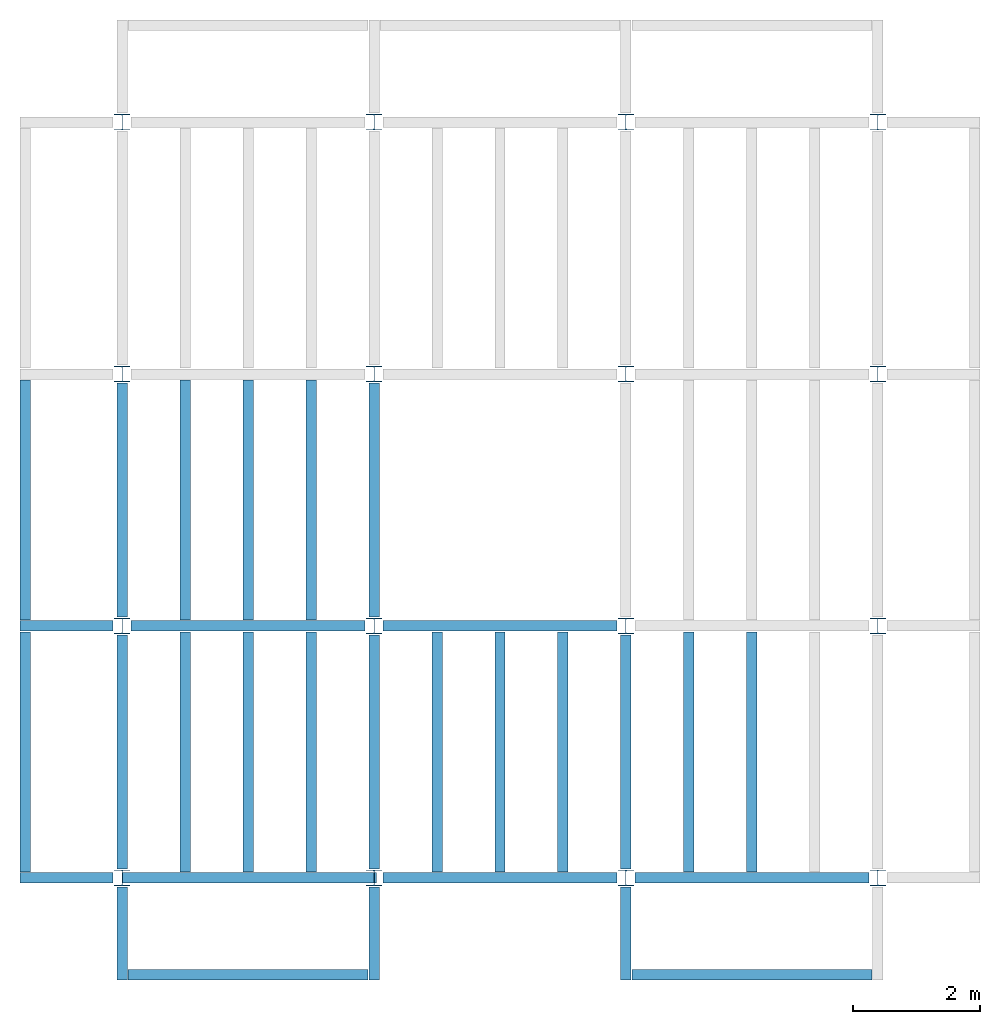
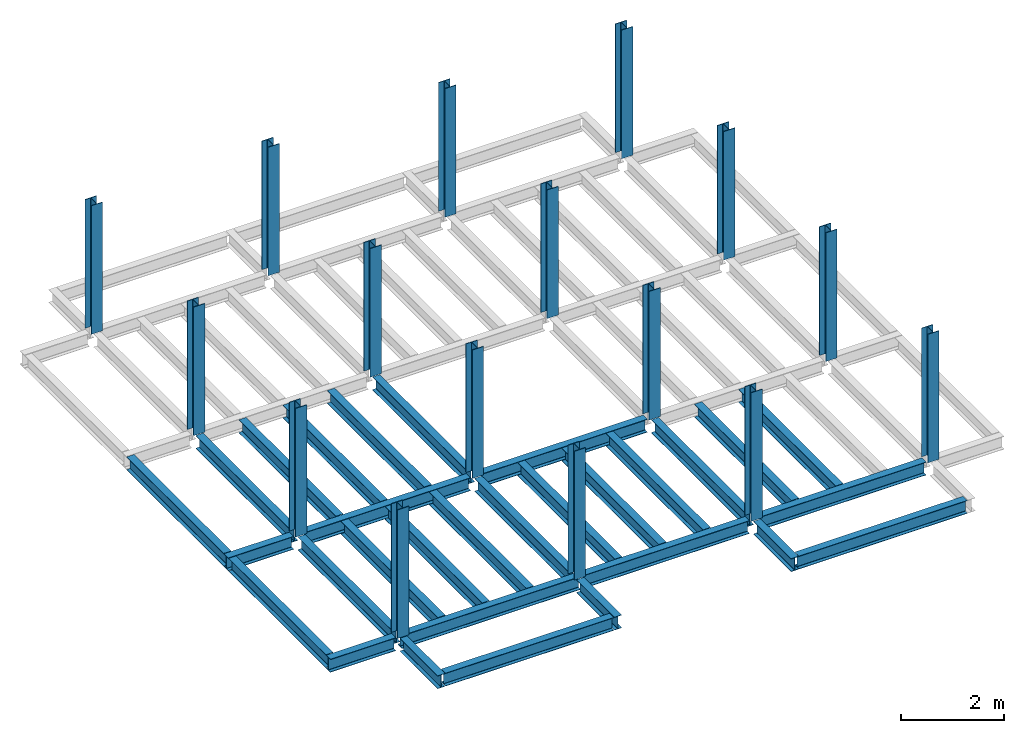
# One storey, part 1 of 3: 30 beams, 16 columns, 4 elements without a shape of their own.
"""IFC4 building model written with IfcOpenShell, lengths in feet."""

from ifc_helpers import new_model, entity, si_unit, converted_unit, derived_unit, direction, frame, origin, origin_2d, place, context, subcontext, project, spatial, line, arc, indexed_curve, i_section, outline, extrude, source, transform, mapped, material, type_object, type_shapes, element, aggregate, save


model = new_model("IFC4")

# Units and contexts
model_context = context("Model", 3, precision=0.0001, world=origin(), true_north=direction((6.123233995736766e-17, 1.0)))
plan_context = context("Plan", 3, precision=0.0001, world=origin(), true_north=direction((6.123233995736766e-17, 1.0)))
body_context = subcontext(model_context, "Body", "Model", "MODEL_VIEW")
ifc_project = project(units=[converted_unit("LENGTHUNIT", "FOOT", entity("IfcLengthMeasure", 0.3048), si_unit("LENGTHUNIT", "METRE"), dimensions=[1, 0, 0, 0, 0, 0, 0]), converted_unit("AREAUNIT", "SQUARE FOOT", entity("IfcAreaMeasure", 0.09290304), si_unit("AREAUNIT", "SQUARE_METRE"), dimensions=[2, 0, 0, 0, 0, 0, 0]), converted_unit("PLANEANGLEUNIT", "DEGREE", entity("IfcPlaneAngleMeasure", 0.017453292519943278), si_unit("PLANEANGLEUNIT", "RADIAN"), dimensions=[0, 0, 0, 0, 0, 0, 0]), converted_unit("VOLUMEUNIT", "CUBIC FOOT", entity("IfcVolumeMeasure", 0.028316846592000004), si_unit("VOLUMEUNIT", "CUBIC_METRE"), dimensions=[3, 0, 0, 0, 0, 0, 0]), si_unit("PRESSUREUNIT", "PASCAL"), derived_unit("MASSDENSITYUNIT", [(si_unit("MASSUNIT", "GRAM", prefix="KILO"), 1), (si_unit("LENGTHUNIT", "METRE"), -3)]), derived_unit("VAPORPERMEABILITYUNIT", [(si_unit("LENGTHUNIT", "METRE"), -1), (si_unit("TIMEUNIT", "SECOND"), 1)]), derived_unit("USERDEFINED", [(si_unit("MASSUNIT", "GRAM", prefix="KILO"), 1), (si_unit("LENGTHUNIT", "METRE"), 3), (si_unit("TIMEUNIT", "SECOND"), -3), (si_unit("ELECTRICCURRENTUNIT", "AMPERE"), -2)]), derived_unit("MODULUSOFELASTICITYUNIT", [(si_unit("MASSUNIT", "GRAM", prefix="KILO"), 1), (si_unit("LENGTHUNIT", "METRE"), -1), (si_unit("TIMEUNIT", "SECOND"), -2)]), derived_unit("THERMALEXPANSIONCOEFFICIENTUNIT", [(si_unit("THERMODYNAMICTEMPERATUREUNIT", "KELVIN"), -1)]), derived_unit("SPECIFICHEATCAPACITYUNIT", [(si_unit("TIMEUNIT", "SECOND"), -2), (si_unit("THERMODYNAMICTEMPERATUREUNIT", "KELVIN"), -1), (si_unit("LENGTHUNIT", "METRE"), 2)]), derived_unit("THERMALCONDUCTANCEUNIT", [(si_unit("MASSUNIT", "GRAM", prefix="KILO"), 1), (si_unit("TIMEUNIT", "SECOND"), -3), (si_unit("THERMODYNAMICTEMPERATUREUNIT", "KELVIN"), -1), (si_unit("LENGTHUNIT", "METRE"), 1)])], contexts=[model_context, plan_context])

# Site, building, storey
site_placement = place(None, origin())
site = spatial("IfcSite", under=ifc_project, at=site_placement, CompositionType="ELEMENT")
building_placement = place(site_placement, origin())
building = spatial("IfcBuilding", under=site, at=building_placement, CompositionType="ELEMENT")
storey_placement = place(building_placement, frame((0.0, 0.0, 29.875)))
storey = spatial("IfcBuildingStorey", under=building, at=storey_placement, Name="STR 04", CompositionType="ELEMENT", Elevation=29.875)

# Columns
ifc_material = material(Name="Steel ASTM A992", Category="Metal")
column_type = type_object("IfcColumnType", Name="W10X49", PredefinedType="COLUMN", material=ifc_material)
shared_shape_1 = source(origin(), body_context, "Body", "SweptSolid", [
    extrude(outline(indexed_curve([(-0.41666666666666663, -0.4166666666666676), (0.41666666666666663, -0.4166666666666676), (0.41666666666666663, -0.3699999999999996), (0.055833333333333846, -0.3699999999999996), (0.02637055078389421, -0.35779611588277277), (0.014166666666666636, -0.32833333333333287), (0.01416666666666665, 0.32833333333333303), (0.026370550783893467, 0.3577961158827727), (0.05583333333333332, 0.3700000000000003), (0.41666666666666663, 0.3700000000000003), (0.41666666666666663, 0.4166666666666656), (-0.41666666666666663, 0.4166666666666656), (-0.41666666666666663, 0.3700000000000003), (-0.05583333333333365, 0.3700000000000003), (-0.02637055078389416, 0.3577961158827734), (-0.014166666666666685, 0.32833333333333387), (-0.014166666666666685, -0.32833333333333264), (-0.026370550783893578, -0.3577961158827721), (-0.055833333333333374, -0.3699999999999996), (-0.41666666666666663, -0.3699999999999996)], segments=[line(1, 2, 3, 4), arc(4, 5, 6), line(6, 7), arc(7, 8, 9), line(9, 10, 11, 12, 13, 14), arc(14, 15, 16), line(16, 17), arc(17, 18, 19), line(19, 20, 1)], self_intersect=False)), frame((0.0, 0.0, 29.875), z_axis=(0.0, 0.0, 1.0), x_axis=(-1.0, 0.0, 0.0)), (0.0, 0.0, 1.0), 10.0),
])
type_shapes(column_type, [shared_shape_1])
for number, where, z_axis, x_axis, name in (
    (1, (0.0, 0.0, -29.875), (0.0, 0.0, 1.0), (-1.0, 0.0, 0.0), "W10X49"),
    (2, (0.0, 13.0, -29.875), (0.0, 0.0, 1.0), (-1.0, 0.0, 0.0), "W10X49"),
    (3, (0.0, 26.0, -29.875), (0.0, 0.0, 1.0), (-1.0, 0.0, 0.0), "W10X49"),
    (4, (0.0, 39.0, -29.875), (0.0, 0.0, 1.0), (-1.0, 0.0, 0.0), "W10X49"),
    (5, (13.0, 0.0, -29.875), (0.0, 0.0, 1.0), (-1.0, 0.0, 0.0), "W10X49"),
    (6, (13.0, 13.0, -29.875), (0.0, 0.0, 1.0), (-1.0, 0.0, 0.0), "W10X49"),
    (7, (13.0, 26.0, -29.875), (0.0, 0.0, 1.0), (-1.0, 0.0, 0.0), "W10X49"),
    (8, (13.0, 39.0, -29.875), (0.0, 0.0, 1.0), (-1.0, 0.0, 0.0), "W10X49"),
    (9, (26.0, 0.0, -29.875), (0.0, 0.0, 1.0), (-1.0, 0.0, 0.0), "W10X49"),
    (10, (26.0, 13.0, -29.875), (0.0, 0.0, 1.0), (-1.0, 0.0, 0.0), "W10X49"),
    (11, (26.0, 26.0, -29.875), (0.0, 0.0, 1.0), (-1.0, 0.0, 0.0), "W10X49"),
    (12, (26.0, 39.0, -29.875), (0.0, 0.0, 1.0), (-1.0, 0.0, 0.0), "W10X49"),
    (13, (39.0, 0.0, -29.875), (0.0, 0.0, 1.0), (-1.0, 0.0, 0.0), "W10X49"),
    (14, (39.0, 13.0, -29.875), (0.0, 0.0, 1.0), (-1.0, 0.0, 0.0), "W10X49"),
    (15, (39.0, 26.0, -29.875), (0.0, 0.0, 1.0), (-1.0, 0.0, 0.0), "W10X49"),
    (16, (39.0, 39.0, -29.875), (0.0, 0.0, 1.0), (-1.0, 0.0, 0.0), "W10X49"),
):
    element("IfcColumn", number, at=place(storey_placement, frame(where, z_axis=z_axis, x_axis=x_axis)), inside=storey, type_object=column_type, material=ifc_material, Name=name, ObjectType="W Shapes-Column:W10X49", PredefinedType="COLUMN", context=body_context, shape_type="MappedRepresentation", body=[
        mapped(shared_shape_1, transform((0.0, 0.0, 0.0), scale=1.0)),
    ])

# Beams
beam_type_1 = type_object("IfcBeamType", Name="W12X26", PredefinedType="JOIST", material=ifc_material)
shared_shape_2 = source(origin(), body_context, "Body", "SweptSolid", [
    extrude(outline(indexed_curve([(-0.27041666666666714, -0.47666666666666574), (-0.27041666666666714, -0.5083333333333351), (0.2704166666666669, -0.5083333333333351), (0.2704166666666669, -0.47666666666666574), (0.03458333333333309, -0.47666666666666574), (0.016905663803669493, -0.46934433619632937), (0.009583333333333202, -0.4516666666666659), (0.0095833333333332, 0.45166666666666705), (0.01690566380366948, 0.4693443361963307), (0.03458333333333325, 0.4766666666666671), (0.2704166666666669, 0.4766666666666671), (0.2704166666666669, 0.5083333333333312), (-0.2704166666666655, 0.5083333333333312), (-0.2704166666666655, 0.4766666666666671), (-0.034583333333333514, 0.47666666666666707), (-0.016905663803669865, 0.46934433619633054), (-0.009583333333333737, 0.45166666666666694), (-0.009583333333333735, -0.4516666666666658), (-0.01690566380367013, -0.4693443361963295), (-0.03458333333333368, -0.47666666666666574)], segments=[line(1, 2, 3, 4, 5), arc(5, 6, 7), line(7, 8), arc(8, 9, 10), line(10, 11, 12, 13, 14, 15), arc(15, 16, 17), line(17, 18), arc(18, 19, 20), line(20, 1)], self_intersect=False)), frame((-6.103346456692914, 0.0, 0.0), z_axis=(-1.0, 0.0, 0.0), x_axis=(0.0, -1.0, 0.0)), (0.0, 0.0, -1.0), 12.083333333333323),
])
type_shapes(beam_type_1, [shared_shape_2])
beam_1_placement = place(storey_placement, frame((6.561679790026266, 13.0, -0.5083333333333329)))
element("IfcBeam", 17, at=beam_1_placement, inside=storey, type_object=beam_type_1, material=ifc_material, Name="W12X26", ObjectType="W Shapes:W12X26", PredefinedType="JOIST", context=body_context, shape_type="MappedRepresentation", body=[
    mapped(shared_shape_2, transform((0.0, 0.0, 0.0), scale=1.0)),
])
for number, where, z_axis, x_axis, name in (
    (18, (0.0, 6.561679790026247, -0.5083333333333329), (0.0, 0.0, 1.0), (0.0, 1.0, 0.0), "W12X26"),
    (19, (26.0, 6.561679790026162, -0.5083333333333329), (0.0, 0.0, 1.0), (0.0, 1.0, 0.0), "W12X26"),
    (20, (13.0, 6.561679790026203, -0.5083333333333329), (0.0, 0.0, 1.0), (0.0, 1.0, 0.0), "W12X26"),
):
    element("IfcBeam", number, at=place(storey_placement, frame(where, z_axis=z_axis, x_axis=x_axis)), inside=storey, type_object=beam_type_1, material=ifc_material, Name=name, ObjectType="W Shapes:W12X26", PredefinedType="JOIST", context=body_context, shape_type="MappedRepresentation", body=[
        mapped(shared_shape_2, transform((0.0, 0.0, 0.0), scale=1.0)),
    ])
beam_type_2 = type_object("IfcBeamType", Name="W12X26", PredefinedType="JOIST", material=ifc_material)
shared_shape_3 = source(origin(), body_context, "Body", "SweptSolid", [
    extrude(outline(indexed_curve([(-0.27041666666666714, -0.47666666666666574), (-0.27041666666666714, -0.5083333333333351), (0.2704166666666669, -0.5083333333333351), (0.2704166666666669, -0.47666666666666574), (0.03458333333333309, -0.47666666666666574), (0.016905663803669493, -0.46934433619632937), (0.009583333333333202, -0.4516666666666659), (0.0095833333333332, 0.45166666666666705), (0.01690566380366948, 0.4693443361963307), (0.03458333333333325, 0.4766666666666671), (0.2704166666666669, 0.4766666666666671), (0.2704166666666669, 0.5083333333333312), (-0.2704166666666655, 0.5083333333333312), (-0.2704166666666655, 0.4766666666666671), (-0.034583333333333514, 0.47666666666666707), (-0.016905663803669865, 0.46934433619633054), (-0.009583333333333737, 0.45166666666666694), (-0.009583333333333735, -0.4516666666666658), (-0.01690566380367013, -0.4693443361963295), (-0.03458333333333368, -0.47666666666666574)], segments=[line(1, 2, 3, 4, 5), arc(5, 6, 7), line(7, 8), arc(8, 9, 10), line(10, 11, 12, 13, 14, 15), arc(15, 16, 17), line(17, 18), arc(18, 19, 20), line(20, 1)], self_intersect=False)), frame((-6.226706036745409, 0.0, 0.0), z_axis=(-1.0, 0.0, 0.0), x_axis=(0.0, -1.0, 0.0)), (0.0, 0.0, -1.0), 12.08333333333333),
])
type_shapes(beam_type_2, [shared_shape_3])
for number, where, name in (
    (21, (19.68503937007876, 13.0, -0.5083333333333329), "W12X26"),
    (22, (19.68503937007874, 0.0, -0.5083333333333329), "W12X26"),
):
    element("IfcBeam", number, at=place(storey_placement, frame(where)), inside=storey, type_object=beam_type_2, material=ifc_material, Name=name, ObjectType="W Shapes:W12X26", PredefinedType="JOIST", context=body_context, shape_type="MappedRepresentation", body=[
        mapped(shared_shape_3, transform((0.0, 0.0, 0.0), scale=1.0)),
    ])
for number, where, z_axis, x_axis, name in (
    (23, (0.0, 19.68503937007874, -0.5083333333333329), (0.0, 0.0, 1.0), (0.0, 1.0, 0.0), "W12X26"),
    (24, (13.0, 19.685039370078698, -0.5083333333333329), (0.0, 0.0, 1.0), (0.0, 1.0, 0.0), "W12X26"),
):
    element("IfcBeam", number, at=place(storey_placement, frame(where, z_axis=z_axis, x_axis=x_axis)), inside=storey, type_object=beam_type_2, material=ifc_material, Name=name, ObjectType="W Shapes:W12X26", PredefinedType="JOIST", context=body_context, shape_type="MappedRepresentation", body=[
        mapped(shared_shape_3, transform((0.0, 0.0, 0.0), scale=1.0)),
    ])

# Assembly, beams
assembly_1_placement = place(storey_placement, origin())
assembly_1 = element("IfcElementAssembly", 25, at=assembly_1_placement, inside=storey, Name="Structural Framing System", ObjectType="Structural Beam System:Structural Framing System", AssemblyPlace="NOTDEFINED", PredefinedType="BEAM_GRID")
beam_type_3 = type_object("IfcBeamType", Name="W12X26", PredefinedType="JOIST", material=ifc_material)
shared_shape_4 = source(origin(), body_context, "Body", "SweptSolid", [
    extrude(outline(indexed_curve([(-0.27041666666666714, -0.47666666666666574), (-0.27041666666666714, -0.5083333333333351), (0.2704166666666669, -0.5083333333333351), (0.2704166666666669, -0.47666666666666574), (0.03458333333333309, -0.47666666666666574), (0.016905663803669493, -0.46934433619632937), (0.009583333333333202, -0.4516666666666659), (0.0095833333333332, 0.45166666666666705), (0.01690566380366948, 0.4693443361963307), (0.03458333333333325, 0.4766666666666671), (0.2704166666666669, 0.4766666666666671), (0.2704166666666669, 0.5083333333333312), (-0.2704166666666655, 0.5083333333333312), (-0.2704166666666655, 0.4766666666666671), (-0.034583333333333514, 0.47666666666666707), (-0.016905663803669865, 0.46934433619633054), (-0.009583333333333737, 0.45166666666666694), (-0.009583333333333735, -0.4516666666666658), (-0.01690566380367013, -0.4693443361963295), (-0.03458333333333368, -0.47666666666666574)], segments=[line(1, 2, 3, 4, 5), arc(5, 6, 7), line(7, 8), arc(8, 9, 10), line(10, 11, 12, 13, 14, 15), arc(15, 16, 17), line(17, 18), arc(18, 19, 20), line(20, 1)], self_intersect=False)), frame((-6.187916666666566, 0.0, 0.0), z_axis=(-1.0, 0.0, 0.0), x_axis=(0.0, -1.0, 0.0)), (0.0, 0.0, -1.0), 12.375833333333075),
])
type_shapes(beam_type_3, [shared_shape_4])
beam_2_placement = place(assembly_1_placement, frame((3.250000000000031, 6.499999999999844, -0.5083333333333329), z_axis=(0.0, 0.0, 1.0), x_axis=(0.0, 1.0, 0.0)))
beam_2 = element("IfcBeam", 26, at=beam_2_placement, type_object=beam_type_3, material=ifc_material, Name="W12X26", ObjectType="W Shapes:W12X26", PredefinedType="JOIST", context=body_context, shape_type="MappedRepresentation", body=[
    mapped(shared_shape_4, transform((0.0, 0.0, 0.0), scale=1.0)),
])
beam_3_placement = place(assembly_1_placement, frame((6.500000000000053, 6.4999999999998455, -0.5083333333333329), z_axis=(0.0, 0.0, 1.0), x_axis=(0.0, 1.0, 0.0)))
beam_3 = element("IfcBeam", 27, at=beam_3_placement, type_object=beam_type_3, material=ifc_material, Name="W12X26", ObjectType="W Shapes:W12X26", PredefinedType="JOIST", context=body_context, shape_type="MappedRepresentation", body=[
    mapped(shared_shape_4, transform((0.0, 0.0, 0.0), scale=1.0)),
])
beam_4_placement = place(assembly_1_placement, frame((9.750000000000075, 6.499999999999844, -0.5083333333333329), z_axis=(0.0, 0.0, 1.0), x_axis=(0.0, 1.0, 0.0)))
beam_4 = element("IfcBeam", 28, at=beam_4_placement, type_object=beam_type_3, material=ifc_material, Name="W12X26", ObjectType="W Shapes:W12X26", PredefinedType="JOIST", context=body_context, shape_type="MappedRepresentation", body=[
    mapped(shared_shape_4, transform((0.0, 0.0, 0.0), scale=1.0)),
])
aggregate(assembly_1, [beam_2, beam_3, beam_4])

assembly_2_placement = place(storey_placement, origin())
assembly_2 = element("IfcElementAssembly", 29, at=assembly_2_placement, inside=storey, Name="Structural Framing System", ObjectType="Structural Beam System:Structural Framing System", AssemblyPlace="NOTDEFINED", PredefinedType="BEAM_GRID")
beam_5_placement = place(assembly_2_placement, frame((3.2500000000000515, 19.49999999999968, -0.5083333333333329), z_axis=(0.0, 0.0, 1.0), x_axis=(0.0, 1.0, 0.0)))
beam_5 = element("IfcBeam", 30, at=beam_5_placement, type_object=beam_type_3, material=ifc_material, Name="W12X26", ObjectType="W Shapes:W12X26", PredefinedType="JOIST", context=body_context, shape_type="MappedRepresentation", body=[
    mapped(shared_shape_4, transform((0.0, 0.0, 0.0), scale=1.0)),
])
beam_6_placement = place(assembly_2_placement, frame((6.500000000000073, 19.499999999999666, -0.5083333333333329), z_axis=(0.0, 0.0, 1.0), x_axis=(0.0, 1.0, 0.0)))
beam_6 = element("IfcBeam", 31, at=beam_6_placement, type_object=beam_type_3, material=ifc_material, Name="W12X26", ObjectType="W Shapes:W12X26", PredefinedType="JOIST", context=body_context, shape_type="MappedRepresentation", body=[
    mapped(shared_shape_4, transform((0.0, 0.0, 0.0), scale=1.0)),
])
beam_7_placement = place(assembly_2_placement, frame((9.750000000000094, 19.49999999999966, -0.5083333333333329), z_axis=(0.0, 0.0, 1.0), x_axis=(0.0, 1.0, 0.0)))
beam_7 = element("IfcBeam", 32, at=beam_7_placement, type_object=beam_type_3, material=ifc_material, Name="W12X26", ObjectType="W Shapes:W12X26", PredefinedType="JOIST", context=body_context, shape_type="MappedRepresentation", body=[
    mapped(shared_shape_4, transform((0.0, 0.0, 0.0), scale=1.0)),
])
aggregate(assembly_2, [beam_5, beam_6, beam_7])

assembly_3_placement = place(storey_placement, origin())
assembly_3 = element("IfcElementAssembly", 33, at=assembly_3_placement, inside=storey, Name="Structural Framing System", ObjectType="Structural Beam System:Structural Framing System", AssemblyPlace="NOTDEFINED", PredefinedType="BEAM_GRID")
beam_8_placement = place(assembly_3_placement, frame((16.250000000000092, 6.499999999999801, -0.5083333333333329), z_axis=(0.0, 0.0, 1.0), x_axis=(0.0, 1.0, 0.0)))
beam_8 = element("IfcBeam", 34, at=beam_8_placement, type_object=beam_type_3, material=ifc_material, Name="W12X26", ObjectType="W Shapes:W12X26", PredefinedType="JOIST", context=body_context, shape_type="MappedRepresentation", body=[
    mapped(shared_shape_4, transform((0.0, 0.0, 0.0), scale=1.0)),
])
beam_9_placement = place(assembly_3_placement, frame((19.5000000000001, 6.499999999999801, -0.5083333333333329), z_axis=(0.0, 0.0, 1.0), x_axis=(0.0, 1.0, 0.0)))
beam_9 = element("IfcBeam", 35, at=beam_9_placement, type_object=beam_type_3, material=ifc_material, Name="W12X26", ObjectType="W Shapes:W12X26", PredefinedType="JOIST", context=body_context, shape_type="MappedRepresentation", body=[
    mapped(shared_shape_4, transform((0.0, 0.0, 0.0), scale=1.0)),
])
beam_10_placement = place(assembly_3_placement, frame((22.750000000000107, 6.499999999999801, -0.5083333333333329), z_axis=(0.0, 0.0, 1.0), x_axis=(0.0, 1.0, 0.0)))
beam_10 = element("IfcBeam", 36, at=beam_10_placement, type_object=beam_type_3, material=ifc_material, Name="W12X26", ObjectType="W Shapes:W12X26", PredefinedType="JOIST", context=body_context, shape_type="MappedRepresentation", body=[
    mapped(shared_shape_4, transform((0.0, 0.0, 0.0), scale=1.0)),
])
aggregate(assembly_3, [beam_8, beam_9, beam_10])

assembly_4_placement = place(storey_placement, origin())
assembly_4 = element("IfcElementAssembly", 37, at=assembly_4_placement, inside=storey, Name="Structural Framing System", ObjectType="Structural Beam System:Structural Framing System", AssemblyPlace="NOTDEFINED", PredefinedType="BEAM_GRID")
beam_11_placement = place(assembly_4_placement, frame((29.2500000000001, 6.49999999999975, -0.5083333333333329), z_axis=(0.0, 0.0, 1.0), x_axis=(0.0, 1.0, 0.0)))
beam_11 = element("IfcBeam", 38, at=beam_11_placement, type_object=beam_type_3, material=ifc_material, Name="W12X26", ObjectType="W Shapes:W12X26", PredefinedType="JOIST", context=body_context, shape_type="MappedRepresentation", body=[
    mapped(shared_shape_4, transform((0.0, 0.0, 0.0), scale=1.0)),
])
beam_12_placement = place(assembly_4_placement, frame((32.5000000000001, 6.499999999999737, -0.5083333333333329), z_axis=(0.0, 0.0, 1.0), x_axis=(0.0, 1.0, 0.0)))
beam_12 = element("IfcBeam", 39, at=beam_12_placement, type_object=beam_type_3, material=ifc_material, Name="W12X26", ObjectType="W Shapes:W12X26", PredefinedType="JOIST", context=body_context, shape_type="MappedRepresentation", body=[
    mapped(shared_shape_4, transform((0.0, 0.0, 0.0), scale=1.0)),
])
aggregate(assembly_4, [beam_11, beam_12])

# Beams
for number, where, z_axis, x_axis, name in (
    (40, (-5.0, 6.499999999999858, -0.5083333333333329), (0.0, 0.0, 1.0), (0.0, -1.0, 0.0), "W12X26"),
    (41, (-5.0, 19.499999999999705, -0.5083333333333329), (0.0, 0.0, 1.0), (0.0, 1.0, 0.0), "W12X26"),
):
    element("IfcBeam", number, at=place(storey_placement, frame(where, z_axis=z_axis, x_axis=x_axis)), inside=storey, type_object=beam_type_3, material=ifc_material, Name=name, ObjectType="W Shapes:W12X26", PredefinedType="JOIST", context=body_context, shape_type="MappedRepresentation", body=[
        mapped(shared_shape_4, transform((0.0, 0.0, 0.0), scale=1.0)),
    ])
beam_type_4 = type_object("IfcBeamType", Name="W12X26", PredefinedType="JOIST", material=ifc_material)
shared_shape_5 = source(origin(), body_context, "Body", "SweptSolid", [
    extrude(outline(indexed_curve([(-0.27041666666666714, -0.47666666666666574), (-0.27041666666666714, -0.5083333333333351), (0.2704166666666669, -0.5083333333333351), (0.2704166666666669, -0.47666666666666574), (0.03458333333333309, -0.47666666666666574), (0.016905663803669493, -0.46934433619632937), (0.009583333333333202, -0.4516666666666659), (0.0095833333333332, 0.45166666666666705), (0.01690566380366948, 0.4693443361963307), (0.03458333333333325, 0.4766666666666671), (0.2704166666666669, 0.4766666666666671), (0.2704166666666669, 0.5083333333333312), (-0.2704166666666655, 0.5083333333333312), (-0.2704166666666655, 0.4766666666666671), (-0.034583333333333514, 0.47666666666666707), (-0.016905663803669865, 0.46934433619633054), (-0.009583333333333737, 0.45166666666666694), (-0.009583333333333735, -0.4516666666666658), (-0.01690566380367013, -0.4693443361963295), (-0.03458333333333368, -0.47666666666666574)], segments=[line(1, 2, 3, 4, 5), arc(5, 6, 7), line(7, 8), arc(8, 9, 10), line(10, 11, 12, 13, 14, 15), arc(15, 16, 17), line(17, 18), arc(18, 19, 20), line(20, 1)], self_intersect=False)), frame((-6.165026246719308, 0.0, 0.0), z_axis=(-1.0, 0.0, 0.0), x_axis=(0.0, -1.0, 0.0)), (0.0, 0.0, -1.0), 12.08333333333334),
])
type_shapes(beam_type_4, [shared_shape_5])
beam_13_placement = place(storey_placement, frame((32.623359580052536, 0.0, -0.5083333333333329)))
element("IfcBeam", 42, at=beam_13_placement, inside=storey, type_object=beam_type_4, material=ifc_material, Name="W12X26", ObjectType="W Shapes:W12X26", PredefinedType="JOIST", context=body_context, shape_type="MappedRepresentation", body=[
    mapped(shared_shape_5, transform((0.0, 0.0, 0.0), scale=1.0)),
])
beam_type_5 = type_object("IfcBeamType", Name="W12X26", PredefinedType="JOIST", material=ifc_material)
shared_shape_6 = source(origin(), body_context, "Body", "SweptSolid", [
    extrude(outline(indexed_curve([(0.47666666666666574, -0.2704166666666672), (0.5083333333333351, -0.2704166666666672), (0.5083333333333351, 0.27041666666666686), (0.47666666666666574, 0.27041666666666686), (0.47666666666666574, 0.03458333333333307), (0.46934433619632937, 0.016905663803669473), (0.4516666666666659, 0.00958333333333318), (-0.45166666666666705, 0.00958333333333318), (-0.4693443361963307, 0.01690566380366946), (-0.4766666666666671, 0.03458333333333323), (-0.4766666666666671, 0.27041666666666686), (-0.5083333333333312, 0.27041666666666686), (-0.5083333333333312, -0.27041666666666553), (-0.4766666666666671, -0.27041666666666553), (-0.47666666666666707, -0.034583333333333535), (-0.46934433619633054, -0.016905663803669885), (-0.45166666666666694, -0.00958333333333376), (0.4516666666666658, -0.009583333333333756), (0.4693443361963295, -0.01690566380367015), (0.47666666666666574, -0.0345833333333337)], segments=[line(1, 2, 3, 4, 5), arc(5, 6, 7), line(7, 8), arc(8, 9, 10), line(10, 11, 12, 13, 14, 15), arc(15, 16, 17), line(17, 18), arc(18, 19, 20), line(20, 1)], self_intersect=False)), frame((-2.0416666666666208, 0.0, 0.0), z_axis=(1.0, 0.0, 0.0), x_axis=(0.0, 0.0, -1.0)), (0.0, 0.0, 1.0), 4.812083333333336),
])
type_shapes(beam_type_5, [shared_shape_6])
for number, where, z_axis, x_axis, name in (
    (43, (26.0, -2.500000000000538, -0.5083333333333329), (0.0, 0.0, 1.0), (0.0, -1.0, 0.0), "W12X26"),
    (44, (-2.499999999999853, 13.0, -0.5083333333333329), (0.0, 0.0, 1.0), (-1.0, 0.0, 0.0), "W12X26"),
    (45, (-2.4999999999998743, 0.0, -0.5083333333333329), (0.0, 0.0, 1.0), (-1.0, 0.0, 0.0), "W12X26"),
):
    element("IfcBeam", number, at=place(storey_placement, frame(where, z_axis=z_axis, x_axis=x_axis)), inside=storey, type_object=beam_type_5, material=ifc_material, Name=name, ObjectType="W Shapes:W12X26", PredefinedType="JOIST", context=body_context, shape_type="MappedRepresentation", body=[
        mapped(shared_shape_6, transform((0.0, 0.0, 0.0), scale=1.0)),
    ])
beam_type_6 = type_object("IfcBeamType", Name="W12X26", PredefinedType="JOIST", material=ifc_material)
shared_shape_7 = source(origin(), body_context, "Body", "SweptSolid", [
    extrude(outline(indexed_curve([(0.47666666666666574, -0.2704166666666672), (0.5083333333333351, -0.2704166666666672), (0.5083333333333351, 0.27041666666666686), (0.47666666666666574, 0.27041666666666686), (0.47666666666666574, 0.03458333333333307), (0.46934433619632937, 0.016905663803669473), (0.4516666666666659, 0.00958333333333318), (-0.45166666666666705, 0.00958333333333318), (-0.4693443361963307, 0.01690566380366946), (-0.4766666666666671, 0.03458333333333323), (-0.4766666666666671, 0.27041666666666686), (-0.5083333333333312, 0.27041666666666686), (-0.5083333333333312, -0.27041666666666553), (-0.4766666666666671, -0.27041666666666553), (-0.47666666666666707, -0.034583333333333535), (-0.46934433619633054, -0.016905663803669885), (-0.45166666666666694, -0.00958333333333376), (0.4516666666666658, -0.009583333333333756), (0.4693443361963295, -0.01690566380367015), (0.47666666666666574, -0.0345833333333337)], segments=[line(1, 2, 3, 4, 5), arc(5, 6, 7), line(7, 8), arc(8, 9, 10), line(10, 11, 12, 13, 14, 15), arc(15, 16, 17), line(17, 18), arc(18, 19, 20), line(20, 1)], self_intersect=False)), frame((-6.187916666666685, 0.0, 0.0), z_axis=(1.0, 0.0, 0.0), x_axis=(0.0, 0.0, -1.0)), (0.0, 0.0, 1.0), 12.375833333333318),
])
type_shapes(beam_type_6, [shared_shape_7])
beam_14_placement = place(storey_placement, frame((32.50000000000002, -5.0, -0.5083333333333329)))
element("IfcBeam", 46, at=beam_14_placement, inside=storey, type_object=beam_type_6, material=ifc_material, Name="W Shapes:W12X26", ObjectType="W Shapes:W12X26", PredefinedType="JOIST", context=body_context, shape_type="MappedRepresentation", body=[
    mapped(shared_shape_7, transform((0.0, 0.0, 0.0), scale=1.0)),
])
beam_type_7 = type_object("IfcBeamType", Name="W12X26", PredefinedType="JOIST", material=ifc_material)
shared_shape_8 = source(origin(), body_context, "Body", "SweptSolid", [
    extrude(outline(indexed_curve([(-0.2704166666666641, -0.5083333333333364), (0.27041666666666764, -0.5083333333333364), (0.27041666666666764, -0.4766666666666737), (0.03458333333333563, -0.4766666666666701), (0.016905663803672866, -0.4693443361963361), (0.009583333333335275, -0.45166666666667155), (0.009583333333337052, 0.4516666666666609), (0.016905663803672866, 0.4693443361963219), (0.03458333333333563, 0.47666666666665947), (0.2704166666666694, 0.47666666666665947), (0.27041666666666764, 0.5083333333333293), (-0.27041666666666586, 0.5083333333333293), (-0.27041666666666586, 0.47666666666665947), (-0.03458333333333208, 0.47666666666665947), (-0.016905663803667537, 0.46934433619632543), (-0.009583333333331723, 0.4516666666666609), (-0.009583333333333499, -0.45166666666667155), (-0.016905663803669313, -0.46934433619633253), (-0.03458333333333208, -0.4766666666666737), (-0.27041666666666586, -0.4766666666666737)], segments=[line(1, 2, 3, 4), arc(4, 5, 6), line(6, 7), arc(7, 8, 9), line(9, 10, 11, 12, 13, 14), arc(14, 15, 16), line(16, 17), arc(17, 18, 19), line(19, 20, 1)], self_intersect=False)), frame((13.0, -0.45833333333387627, 29.366666666666646), z_axis=(0.0, -1.0, 0.0), x_axis=(-1.0, 0.0, 0.0)), (0.0, 0.0, 1.0), 4.812083333333337),
])
type_shapes(beam_type_7, [shared_shape_8])
beam_15_placement = place(storey_placement, frame((0.0, 0.0, -29.875)))
element("IfcBeam", 47, at=beam_15_placement, inside=storey, type_object=beam_type_7, material=ifc_material, Name="W12X26", ObjectType="W Shapes:W12X26", PredefinedType="JOIST", context=body_context, shape_type="MappedRepresentation", body=[
    mapped(shared_shape_8, transform((0.0, 0.0, 0.0), scale=1.0)),
])
beam_type_8 = type_object("IfcBeamType", Name="W12X26", PredefinedType="JOIST", material=ifc_material)
shared_shape_9 = source(origin(), body_context, "Body", "SweptSolid", [
    extrude(outline(indexed_curve([(-0.5083333333333329, -0.270416666666665), (-0.4766666666666701, -0.270416666666665), (-0.47666666666666657, -0.034583333333333854), (-0.46934433619633253, -0.016905663803669313), (-0.451666666666668, -0.009583333333333499), (0.45166666666666444, -0.009583333333333499), (0.469344336196329, -0.016905663803669313), (0.476666666666663, -0.034583333333332966), (0.476666666666663, -0.27041666666666675), (0.5083333333333329, -0.27041666666666675), (0.5083333333333329, 0.27041666666666675), (0.476666666666663, 0.27041666666666764), (0.476666666666663, 0.034583333333333854), (0.469344336196329, 0.016905663803669313), (0.45166666666666444, 0.009583333333333499), (-0.451666666666668, 0.009583333333333499), (-0.46934433619633253, 0.016905663803669313), (-0.4766666666666701, 0.034583333333332966), (-0.4766666666666701, 0.27041666666666675), (-0.5083333333333329, 0.27041666666666764)], segments=[line(1, 2, 3), arc(3, 4, 5), line(5, 6), arc(6, 7, 8), line(8, 9, 10, 11, 12, 13), arc(13, 14, 15), line(15, 16), arc(16, 17, 18), line(18, 19, 20, 1)], self_intersect=False)), frame((0.3120833333333186, -5.0, 29.36666666666665), z_axis=(1.0, 0.0, 0.0), x_axis=(0.0, 0.0, -1.0)), (0.0, 0.0, 1.0), 12.37583333333332),
])
type_shapes(beam_type_8, [shared_shape_9])
beam_16_placement = place(storey_placement, frame((0.0, 0.0, -29.875)))
element("IfcBeam", 48, at=beam_16_placement, inside=storey, type_object=beam_type_8, material=ifc_material, Name="W Shapes:W12X26", ObjectType="W Shapes:W12X26", PredefinedType="JOIST", context=body_context, shape_type="MappedRepresentation", body=[
    mapped(shared_shape_9, transform((0.0, 0.0, 0.0), scale=1.0)),
])
beam_type_9 = type_object("IfcBeamType", Name="W12X26", PredefinedType="JOIST", material=ifc_material)
shared_shape_10 = source(origin(), body_context, "Body", "SweptSolid", [
    extrude(outline(indexed_curve([(-0.27041666666666686, -0.5083333333333364), (0.27041666666666553, -0.5083333333333364), (0.27041666666666553, -0.4766666666666737), (0.034583333333333535, -0.4766666666666701), (0.01690566380366997, -0.4693443361963361), (0.009583333333333712, -0.45166666666667155), (0.009583333333333974, 0.4516666666666609), (0.016905663803669285, 0.46934433619632543), (0.0345833333333337, 0.47666666666665947), (0.2704166666666672, 0.47666666666665947), (0.2704166666666672, 0.5083333333333293), (-0.27041666666666686, 0.5083333333333293), (-0.27041666666666686, 0.47666666666665947), (-0.03458333333333309, 0.47666666666665947), (-0.016905663803668643, 0.46934433619632543), (-0.009583333333333175, 0.4516666666666609), (-0.009583333333333433, -0.45166666666667155), (-0.01690566380366867, -0.4693443361963361), (-0.0345833333333332, -0.4766666666666737), (-0.27041666666666686, -0.4766666666666737)], segments=[line(1, 2, 3, 4), arc(4, 5, 6), line(6, 7), arc(7, 8, 9), line(9, 10, 11, 12, 13, 14), arc(14, 15, 16), line(16, 17), arc(17, 18, 19), line(19, 20, 1)], self_intersect=False)), frame((0.0, -0.45833333333383364, 29.366666666666646), z_axis=(0.0, -1.0, 0.0), x_axis=(-1.0, 0.0, 0.0)), (0.0, 0.0, 1.0), 4.812083333333337),
])
type_shapes(beam_type_9, [shared_shape_10])
beam_17_placement = place(storey_placement, frame((0.0, 0.0, -29.875)))
element("IfcBeam", 49, at=beam_17_placement, inside=storey, type_object=beam_type_9, material=ifc_material, Name="W12X26", ObjectType="W Shapes:W12X26", PredefinedType="JOIST", context=body_context, shape_type="MappedRepresentation", body=[
    mapped(shared_shape_10, transform((0.0, 0.0, 0.0), scale=1.0)),
])
beam_type_10 = type_object("IfcBeamType", Name="W12X26", PredefinedType="BEAM")
beam_18_placement = place(storey_placement, frame((0.0, 0.0, -0.5083333333333364), z_axis=(-1.0, 0.0, 0.0), x_axis=(0.0, -1.0, 0.0)))
element("IfcBeam", 50, at=beam_18_placement, inside=storey, type_object=beam_type_10, material=ifc_material, Name="W12X26", ObjectType="W12X26", context=model_context, shape_type="SweptSolid", body=[
    extrude(i_section(OverallWidth=0.5408333333333333, OverallDepth=1.0166666666666666, WebThickness=0.019166666666666665, FlangeThickness=0.03166666666666666, FilletRadius=0.024999999999999998, at=origin_2d()), origin(), (0.0, 0.0, -1.0), 13.123359580052494),
])

save(model, "model.ifc")
